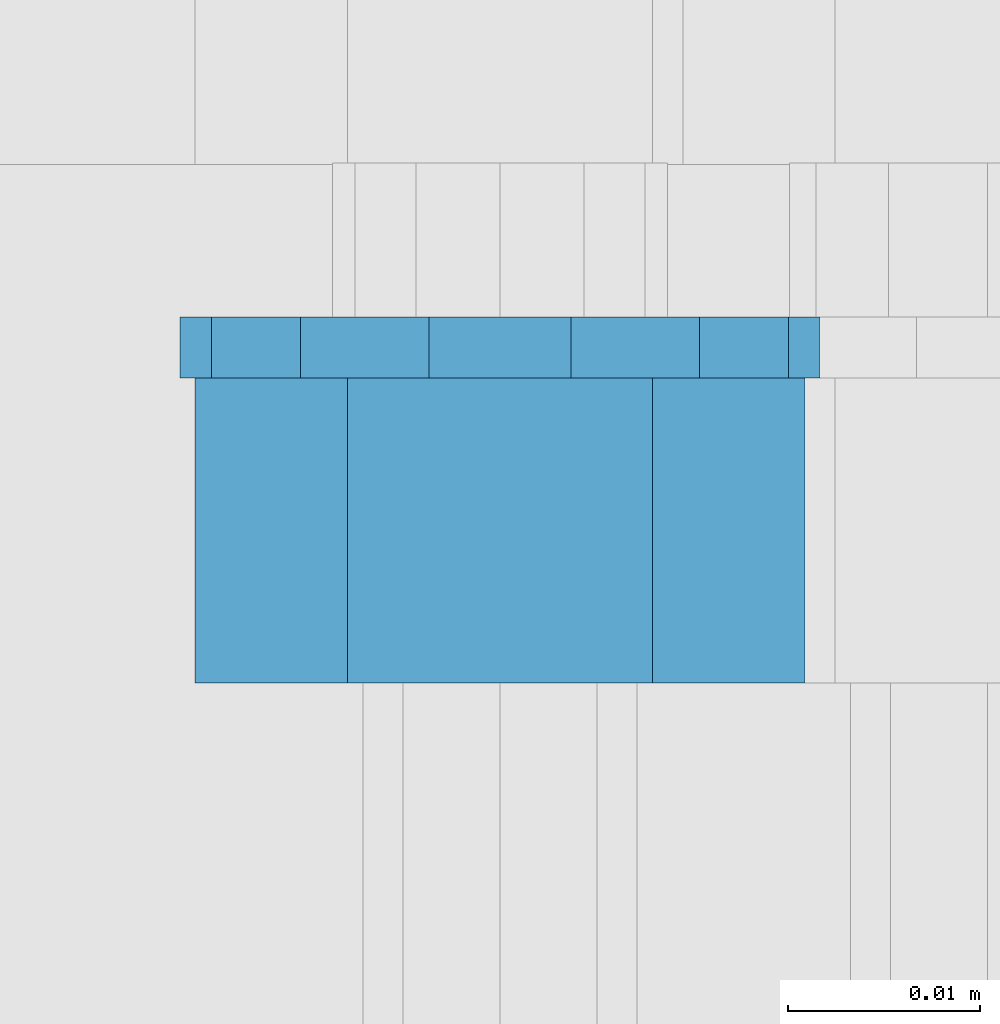
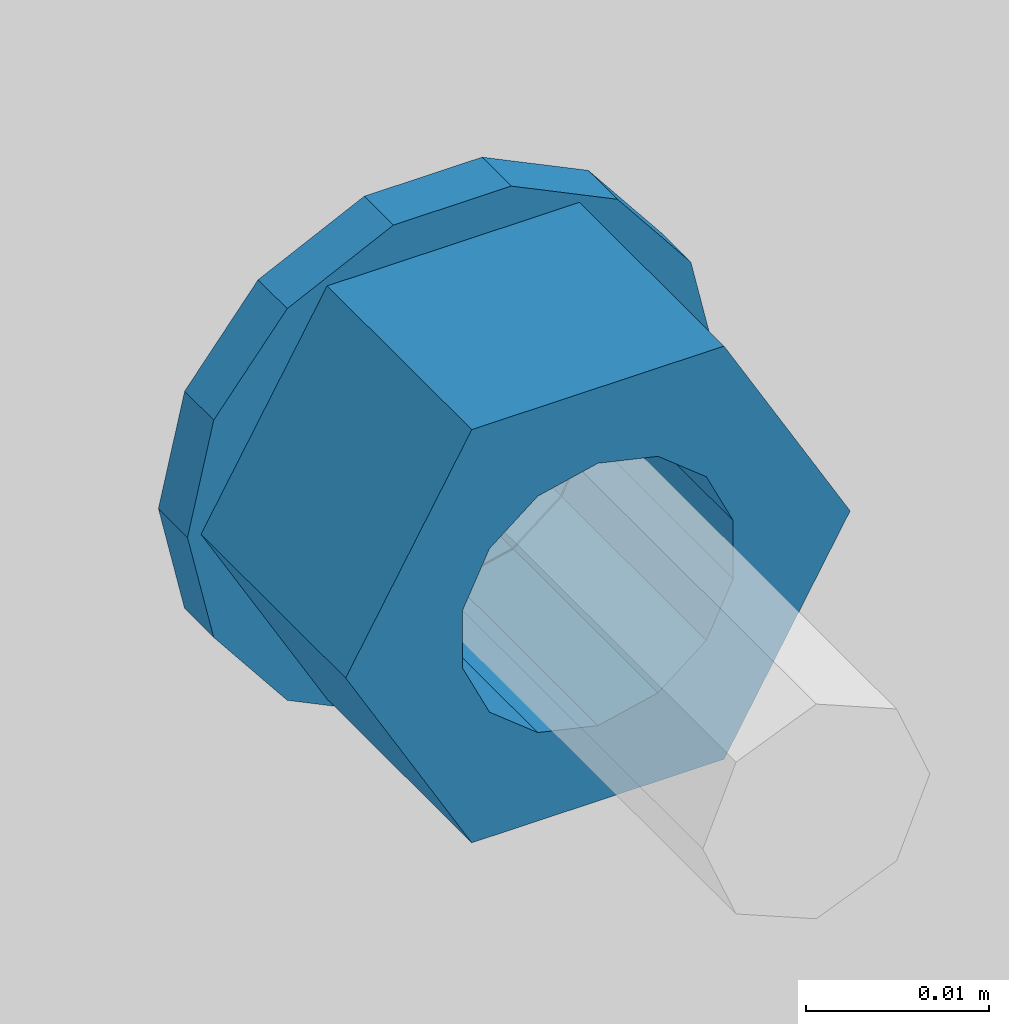
# One storey, part 622 of 975: 2 beams.
"""IFC2X3 building model written with IfcOpenShell, lengths in millimetres."""

from ifc_helpers import new_model, si_unit, frame, origin_with_axes, place, context, subcontext, project, spatial, faceted_brep, material, type_object, element, save


model = new_model("IFC2X3")

# Units and contexts
model_context = context("Model", 3, precision=1e-05, world=origin_with_axes())
body_context = subcontext(model_context, "Body", "Model", "MODEL_VIEW")
ifc_project = project(units=[si_unit("LENGTHUNIT", "METRE", prefix="MILLI"), si_unit("AREAUNIT", "SQUARE_METRE"), si_unit("VOLUMEUNIT", "CUBIC_METRE"), si_unit("MASSUNIT", "GRAM", prefix="KILO"), si_unit("TIMEUNIT", "SECOND"), si_unit("PLANEANGLEUNIT", "RADIAN"), si_unit("SOLIDANGLEUNIT", "STERADIAN"), si_unit("THERMODYNAMICTEMPERATUREUNIT", "DEGREE_CELSIUS"), si_unit("LUMINOUSINTENSITYUNIT", "LUMEN")], contexts=[model_context])

# Site, building, storey
site_placement = place(None, origin_with_axes())
site = spatial("IfcSite", under=ifc_project, at=site_placement, CompositionType="ELEMENT")
building_placement = place(site_placement, origin_with_axes())
building = spatial("IfcBuilding", under=site, at=building_placement, Name="Undefined", CompositionType="ELEMENT")
storey_placement = place(building_placement, origin_with_axes())
storey = spatial("IfcBuildingStorey", under=building, at=storey_placement, Name="Undefined", CompositionType="ELEMENT", Elevation=0.0)

# Beams
ifc_material = material(Name="STEEL/A36")
beam_type_1 = type_object("IfcBeamType", Name="5/8_HEAVY_HEX_NUT", PredefinedType="NOTDEFINED")
beam_1_placement = place(storey_placement, frame((11868.1499511683, 20416.8375, 3886.2), z_axis=(0.0, 0.0, -1.0), x_axis=(0.0, 1.0, 0.0)))
element("IfcBeam", 1, at=beam_1_placement, inside=storey, type_object=beam_type_1, material=ifc_material, Name="NUT", ObjectType="5/8_HEAVY_HEX_NUT", context=body_context, shape_type="Brep", body=[
    faceted_brep([(-1.09139364212751e-11, -15.8800001144436, -2.72848410531878e-12), (1.45519152283669e-11, -7.94000005722046, -13.7500000000036), (15.8750000000146, -7.94000005722137, -13.7500000000045), (15.8749999999891, -15.8800001144446, -2.72848410531878e-12), (2.91038304567337e-11, 7.94000005722319, -13.7500000000027), (15.8750000000291, 7.94000005722319, -13.7500000000027), (2.18278728425503e-11, 15.8800001144436, 9.09494701772928e-13), (15.8750000000218, 15.8800001144427, 9.09494701772928e-13), (-7.27595761418343e-12, 7.94000005722046, 13.7500000000027), (15.8749999999927, 7.94000005722046, 13.7500000000027), (-2.18278728425503e-11, -7.94000005722228, 13.7500000000009), (15.8749999999782, -7.94000005722319, 13.7500000000009), (-7.27595761418343e-12, 0.0, 8.72999954223724), (0.0, 3.78780484388062, 7.86545780435881), (15.875, 3.78780484387971, 7.86545780435881), (15.8749999999927, -9.09494701772928e-13, 8.72999954223724), (7.27595761418343e-12, 6.82538848405238, 5.44306568481716), (15.8750000000073, 6.82538848405238, 5.44306568481716), (1.09139364212751e-11, 8.51112022706275, 1.94260765157742), (15.8750000000109, 8.51112022706093, 1.94260765157651), (1.45519152283669e-11, 8.51112022706184, -1.94260765157651), (15.8750000000146, 8.51112022706184, -1.94260765157651), (2.18278728425503e-11, 6.8253884840542, -5.44306568481716), (15.8750000000218, 6.82538848405238, -5.44306568481716), (1.81898940354586e-11, 3.78780484388153, -7.86545780435881), (15.8750000000182, 3.78780484388062, -7.86545780435881), (1.81898940354586e-11, 9.09494701772928e-13, -8.72999954223997), (15.8750000000182, 9.09494701772928e-13, -8.72999954223997), (1.09139364212751e-11, -3.78780484387971, -7.86545780436063), (15.8750000000109, -3.78780484388062, -7.86545780436063), (3.63797880709171e-12, -6.82538848405238, -5.44306568481807), (15.8750000000036, -6.82538848405329, -5.44306568481807), (0.0, -8.51112022706184, -1.94260765157833), (15.875, -8.51112022706184, -1.94260765157833), (-7.27595761418343e-12, -8.51112022706184, 1.9426076515756), (15.8749999999927, -8.51112022706275, 1.9426076515756), (-1.09139364212751e-11, -6.82538848405329, 5.44306568481534), (15.8749999999927, -6.8253884840542, 5.44306568481534), (-7.27595761418343e-12, -3.78780484388062, 7.8654578043579), (15.8749999999927, -3.78780484388153, 7.8654578043579)], [[[0, 1, 2, 3]], [[1, 4, 5, 2]], [[4, 6, 7, 5]], [[6, 8, 9, 7]], [[8, 10, 11, 9]], [[10, 0, 3, 11]], [[12, 13, 14, 15]], [[13, 16, 17, 14]], [[16, 18, 19, 17]], [[18, 20, 21, 19]], [[20, 22, 23, 21]], [[22, 24, 25, 23]], [[24, 26, 27, 25]], [[26, 28, 29, 27]], [[28, 30, 31, 29]], [[30, 32, 33, 31]], [[32, 34, 35, 33]], [[34, 36, 37, 35]], [[36, 38, 39, 37]], [[38, 12, 15, 39]], [[5, 7, 9, 11, 3, 2], [17, 19, 21, 23, 25, 27, 29, 31, 33, 35, 37, 39, 15, 14]], [[10, 8, 6, 4, 1, 0], [38, 36, 34, 32, 30, 28, 26, 24, 22, 20, 18, 16, 13, 12]]]),
])
beam_type_2 = type_object("IfcBeamType", Name="5/8_WASHER", PredefinedType="NOTDEFINED")
beam_2_placement = place(storey_placement, frame((11868.1499511684, 20432.7125, 3886.2), z_axis=(0.0, 0.0, -1.0), x_axis=(0.0, 1.0, 0.0)))
element("IfcBeam", 2, at=beam_2_placement, inside=storey, type_object=beam_type_2, material=ifc_material, Name="WASHER", ObjectType="5/8_WASHER", context=body_context, shape_type="Brep", body=[
    faceted_brep([(1.09139364212751e-11, -16.670000076293, -2.72848410531878e-12), (2.18278728425503e-11, -15.0191510966704, -7.23284196419536), (3.1750000000211, -15.0191510966711, -7.23284196419627), (3.17500000001019, -16.6700000762937, -1.81898940354586e-12), (2.91038304567337e-11, -10.3935750445523, -13.0331308723944), (3.17500000002838, -10.3935750445526, -13.0331308723953), (2.91038304567337e-11, -3.70942398602756, -16.2520483704566), (3.17500000002838, -3.70942398602779, -16.2520483704566), (2.5465851649642e-11, 3.70942398602961, -16.2520483704557), (3.17500000002474, 3.70942398602961, -16.2520483704566), (1.45519152283669e-11, 10.3935750445542, -13.0331308723935), (3.17500000001382, 10.3935750445537, -13.0331308723944), (0.0, 15.0191510966717, -7.23284196419354), (3.17499999999927, 15.0191510966713, -7.23284196419354), (-7.27595761418343e-12, 16.6700000762933, 0.0), (3.174999999992, 16.6700000762928, -9.09494701772928e-13), (-1.81898940354586e-11, 15.0191510966706, 7.23284196419354), (3.17499999998108, 15.0191510966704, 7.23284196419354), (-2.5465851649642e-11, 10.3935750445519, 13.0331308723926), (3.17499999997381, 10.3935750445517, 13.0331308723926), (-2.5465851649642e-11, 3.70942398602733, 16.2520483704538), (3.17499999997381, 3.7094239860271, 16.2520483704529), (-2.18278728425503e-11, -3.70942398602983, 16.2520483704529), (3.17499999997744, -3.70942398603006, 16.2520483704538), (-1.09139364212751e-11, -10.3935750445542, 13.0331308723908), (3.17499999998836, -10.3935750445544, 13.0331308723908), (0.0, -15.0191510966717, 7.23284196419172), (3.17499999999927, -15.019151096672, 7.23284196419081), (-7.27595761418343e-12, 0.0, 8.72999954223724), (0.0, 3.78780484388062, 7.86545780435881), (3.17499999998472, 3.78780484387903, 7.86545780435699), (3.17499999998836, -9.09494701772928e-13, 8.72999954223542), (7.27595761418343e-12, 6.82538848405238, 5.44306568481716), (3.17499999998836, 6.82538848405102, 5.44306568481534), (1.09139364212751e-11, 8.51112022706275, 1.94260765157742), (3.174999999992, 8.51112022705979, 1.94260765157651), (1.45519152283669e-11, 8.51112022706184, -1.94260765157651), (3.17499999999563, 8.51112022706025, -1.94260765157742), (2.18278728425503e-11, 6.8253884840542, -5.44306568481716), (3.17500000000655, 6.8253884840517, -5.44306568481807), (1.81898940354586e-11, 3.78780484388153, -7.86545780435881), (3.17500000001019, 3.78780484388017, -7.86545780435972), (1.81898940354586e-11, 9.09494701772928e-13, -8.72999954223997), (3.17500000001382, 6.82121026329696e-13, -8.72999954223997), (1.09139364212751e-11, -3.78780484387971, -7.86545780436063), (3.17500000001382, -3.78780484387994, -7.86545780436063), (3.63797880709171e-12, -6.82538848405238, -5.44306568481807), (3.17500000001019, -6.82538848405147, -5.44306568481898), (0.0, -8.51112022706184, -1.94260765157833), (3.17500000001019, -8.5111202270607, -1.94260765157924), (-7.27595761418343e-12, -8.51112022706184, 1.9426076515756), (3.17500000000291, -8.51112022706093, 1.94260765157469), (-1.09139364212751e-11, -6.82538848405329, 5.44306568481534), (3.17499999999563, -6.82538848405238, 5.44306568481534), (-7.27595761418343e-12, -3.78780484388062, 7.8654578043579), (3.174999999992, -3.78780484388085, 7.86545780435699)], [[[0, 1, 2, 3]], [[1, 4, 5, 2]], [[4, 6, 7, 5]], [[6, 8, 9, 7]], [[8, 10, 11, 9]], [[10, 12, 13, 11]], [[12, 14, 15, 13]], [[14, 16, 17, 15]], [[16, 18, 19, 17]], [[18, 20, 21, 19]], [[20, 22, 23, 21]], [[22, 24, 25, 23]], [[24, 26, 27, 25]], [[26, 0, 3, 27]], [[28, 29, 30, 31]], [[29, 32, 33, 30]], [[32, 34, 35, 33]], [[34, 36, 37, 35]], [[36, 38, 39, 37]], [[38, 40, 41, 39]], [[40, 42, 43, 41]], [[42, 44, 45, 43]], [[44, 46, 47, 45]], [[46, 48, 49, 47]], [[48, 50, 51, 49]], [[50, 52, 53, 51]], [[52, 54, 55, 53]], [[54, 28, 31, 55]], [[5, 7, 9, 11, 13, 15, 17, 19, 21, 23, 25, 27, 3, 2], [33, 35, 37, 39, 41, 43, 45, 47, 49, 51, 53, 55, 31, 30]], [[26, 24, 22, 20, 18, 16, 14, 12, 10, 8, 6, 4, 1, 0], [54, 52, 50, 48, 46, 44, 42, 40, 38, 36, 34, 32, 29, 28]]]),
])

save(model, "model.ifc")
